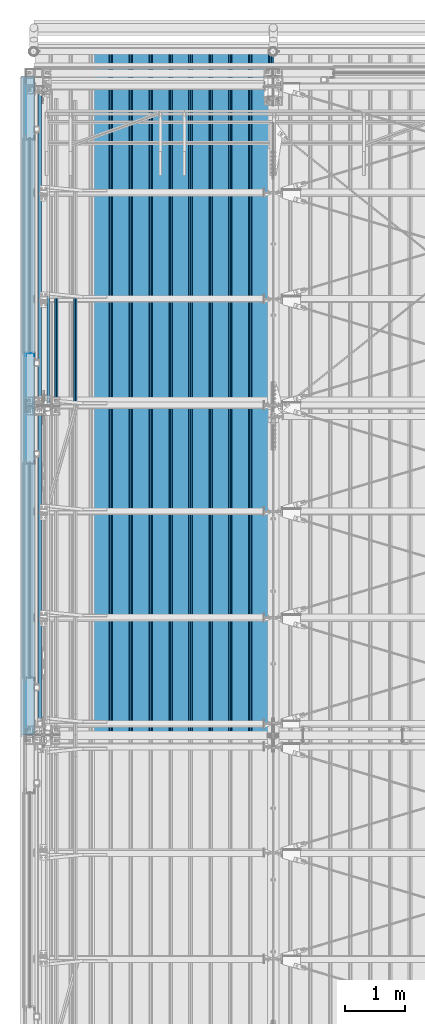
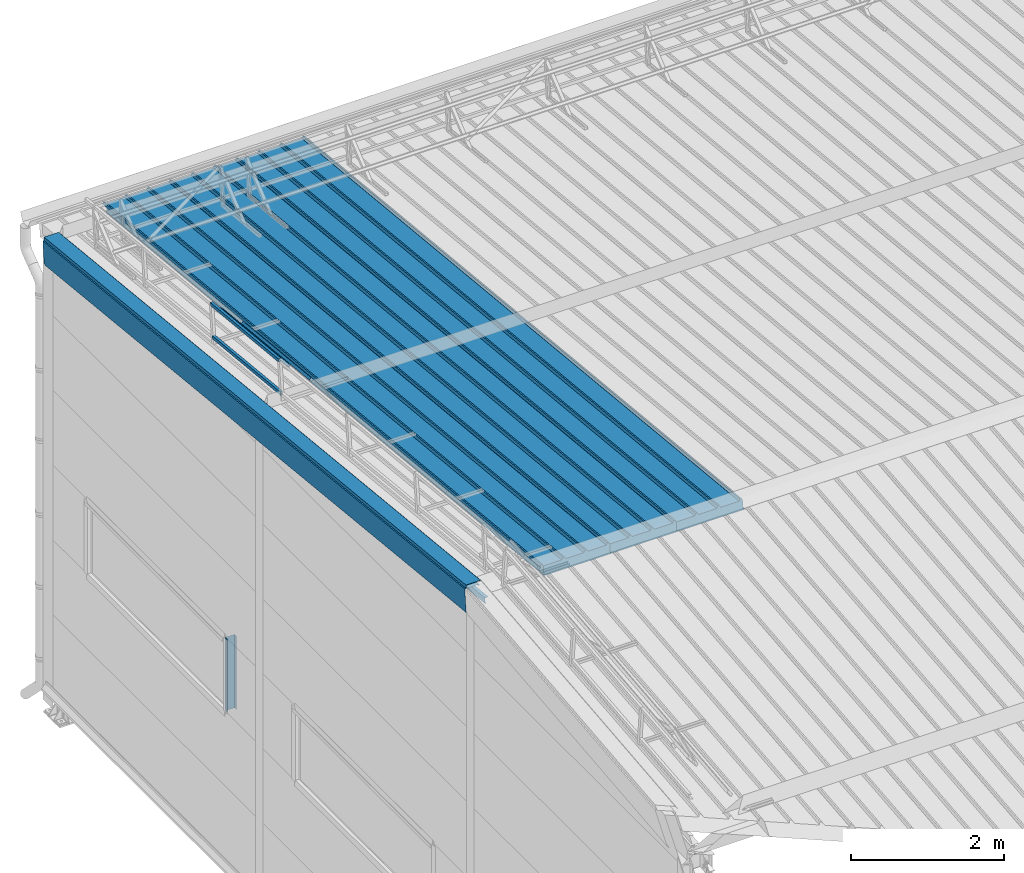
# One storey, part 48 of 709: 11 beams, 11 elements without a shape of their own.
"""IFC4 building model written with IfcOpenShell, lengths in millimetres."""

from ifc_helpers import new_model, si_unit, direction, frame, origin_with_axes, place, context, subcontext, project, spatial, line, indexed_curve, outline, extrude, material, element, aggregate, save


model = new_model("IFC4")

# Units and contexts
model_context = context("Model", 3, precision=0.2, world=origin_with_axes(), true_north=direction((0.0, 1.0)))
body_context = subcontext(model_context, "Body", "Model", "MODEL_VIEW")
ifc_project = project(units=[si_unit("LENGTHUNIT", "METRE", prefix="MILLI"), si_unit("AREAUNIT", "SQUARE_METRE"), si_unit("VOLUMEUNIT", "CUBIC_METRE"), si_unit("MASSUNIT", "GRAM", prefix="KILO"), si_unit("TIMEUNIT", "SECOND"), si_unit("PLANEANGLEUNIT", "RADIAN"), si_unit("SOLIDANGLEUNIT", "STERADIAN"), si_unit("THERMODYNAMICTEMPERATUREUNIT", "DEGREE_CELSIUS"), si_unit("LUMINOUSINTENSITYUNIT", "LUMEN")], contexts=[model_context])

# Site, building, storey
site_placement = place(None, origin_with_axes())
site = spatial("IfcSite", under=ifc_project, at=site_placement, CompositionType="ELEMENT")
building_placement = place(site_placement, origin_with_axes())
building = spatial("IfcBuilding", under=site, at=building_placement, Name="Undefined", CompositionType="ELEMENT")
storey_placement = place(building_placement, origin_with_axes())
storey = spatial("IfcBuildingStorey", under=building, at=storey_placement, Name="Undefined", CompositionType="ELEMENT", Elevation=0.0)

# Assembly, beam
assembly_1_placement = place(storey_placement, frame((3452.44, 11009.10459, 8419.96887), z_axis=(1.0, 0.0, 0.0), x_axis=(0.0, 0.9950371902, -0.099503719)))
assembly_1 = element("IfcElementAssembly", 1, at=assembly_1_placement, inside=storey)
ifc_material_1 = material(Name="Insulation", Category="Insulation")
beam_1_placement = place(assembly_1_placement, origin_with_axes())
beam_1 = element("IfcBeam", 2, at=beam_1_placement, material=ifc_material_1, ObjectType="P-99", context=body_context, shape_type="SolidModel", body=[
    extrude(outline(indexed_curve([(-509.8453, 89.5), (-490.1547, 89.5), (-471.67949, 57.5), (-471.67949, -88.5), (-436.67949, -88.5), (-436.67949, -91.5), (562.55841, -91.5), (562.55841, -89.5), (527.55841, -89.5), (527.55841, 57.5), (510.2379, 88.5), (489.7621, 88.5), (472.44159, 58.5), (196.71923, 58.5), (177.66667, 91.5), (155.66667, 91.5), (136.61411, 58.5), (-136.61411, 58.5), (-155.66667, 91.5), (-177.66667, 91.5), (-196.71923, 58.5), (-469.94744, 58.5), (-489.0, 91.5), (-511.0, 91.5), (-527.16581, 63.5), (-525.43376, 62.5)], segments=[line(1, 2, 3, 4, 5, 6, 7, 8, 9, 10, 11, 12, 13, 14, 15, 16, 17, 18, 19, 20, 21, 22, 23, 24, 25, 26, 1)])), frame((0.0, 0.0, 0.0), z_axis=(-1.0, 0.0, 0.0), x_axis=(0.0, 0.0, 1.0)), (0.0, 0.0, -1.0), 11459.0),
])
aggregate(assembly_1, [beam_1])

assembly_2_placement = place(storey_placement, frame((2452.44, 11009.10459, 8419.96887), z_axis=(1.0, 0.0, 0.0), x_axis=(0.0, 0.9950371902, -0.099503719)))
assembly_2 = element("IfcElementAssembly", 3, at=assembly_2_placement, inside=storey)
beam_2_placement = place(assembly_2_placement, origin_with_axes())
beam_2 = element("IfcBeam", 4, at=beam_2_placement, material=ifc_material_1, ObjectType="P-99", context=body_context, shape_type="SolidModel", body=[
    extrude(outline(indexed_curve([(-509.8453, 89.5), (-490.1547, 89.5), (-471.67949, 57.5), (-471.67949, -88.5), (-436.67949, -88.5), (-436.67949, -91.5), (562.55841, -91.5), (562.55841, -89.5), (527.55841, -89.5), (527.55841, 57.5), (510.2379, 88.5), (489.7621, 88.5), (472.44159, 58.5), (196.71923, 58.5), (177.66667, 91.5), (155.66667, 91.5), (136.61411, 58.5), (-136.61411, 58.5), (-155.66667, 91.5), (-177.66667, 91.5), (-196.71923, 58.5), (-469.94744, 58.5), (-489.0, 91.5), (-511.0, 91.5), (-527.16581, 63.5), (-525.43376, 62.5)], segments=[line(1, 2, 3, 4, 5, 6, 7, 8, 9, 10, 11, 12, 13, 14, 15, 16, 17, 18, 19, 20, 21, 22, 23, 24, 25, 26, 1)])), frame((0.0, 0.0, 0.0), z_axis=(-1.0, 0.0, 0.0), x_axis=(0.0, 0.0, 1.0)), (0.0, 0.0, -1.0), 11459.0),
])
aggregate(assembly_2, [beam_2])

assembly_3_placement = place(storey_placement, frame((1452.44, 11009.10459, 8419.96887), z_axis=(1.0, 0.0, 0.0), x_axis=(0.0, 0.9950371902, -0.099503719)))
assembly_3 = element("IfcElementAssembly", 5, at=assembly_3_placement, inside=storey)
beam_3_placement = place(assembly_3_placement, origin_with_axes())
beam_3 = element("IfcBeam", 6, at=beam_3_placement, material=ifc_material_1, ObjectType="P-99", context=body_context, shape_type="SolidModel", body=[
    extrude(outline(indexed_curve([(-509.8453, 89.5), (-490.1547, 89.5), (-471.67949, 57.5), (-471.67949, -88.5), (-436.67949, -88.5), (-436.67949, -91.5), (562.55841, -91.5), (562.55841, -89.5), (527.55841, -89.5), (527.55841, 57.5), (510.2379, 88.5), (489.7621, 88.5), (472.44159, 58.5), (196.71923, 58.5), (177.66667, 91.5), (155.66667, 91.5), (136.61411, 58.5), (-136.61411, 58.5), (-155.66667, 91.5), (-177.66667, 91.5), (-196.71923, 58.5), (-469.94744, 58.5), (-489.0, 91.5), (-511.0, 91.5), (-527.16581, 63.5), (-525.43376, 62.5)], segments=[line(1, 2, 3, 4, 5, 6, 7, 8, 9, 10, 11, 12, 13, 14, 15, 16, 17, 18, 19, 20, 21, 22, 23, 24, 25, 26, 1)])), frame((0.0, 0.0, 0.0), z_axis=(-1.0, 0.0, 0.0), x_axis=(0.0, 0.0, 1.0)), (0.0, 0.0, -1.0), 11459.0),
])
aggregate(assembly_3, [beam_3])

assembly_4_placement = place(storey_placement, frame((240.0, 16604.47891, 8622.71451), z_axis=(1.0, 0.0, 0.0), x_axis=(0.0, 0.9950371902, -0.099503719)))
assembly_4 = element("IfcElementAssembly", 7, at=assembly_4_placement, inside=storey)
ifc_material_2 = material(Name="Steel_Undefined", Category="STEEL")
beam_4_placement = place(assembly_4_placement, origin_with_axes())
beam_4 = element("IfcBeam", 8, at=beam_4_placement, material=ifc_material_2, ObjectType="609", context=body_context, shape_type="SolidModel", body=[
    extrude(outline(indexed_curve([(-20.0, -25.0), (20.0, -25.0), (20.0, -22.5), (-17.5, -22.5), (-17.5, 22.5), (20.0, 22.5), (20.0, 25.0), (-20.0, 25.0)], segments=[line(1, 2, 3, 4, 5, 6, 7, 8, 1)])), frame((0.0, 0.0, 0.0), z_axis=(-1.0, 0.0, 0.0), x_axis=(0.0, 0.0, 1.0)), (0.0, 0.0, -1.0), 1785.56115),
])
aggregate(assembly_4, [beam_4])

assembly_5_placement = place(storey_placement, frame((240.0, 16554.72705, 8125.19591), z_axis=(1.0, 0.0, 0.0), x_axis=(0.0, 0.9950371902, -0.099503719)))
assembly_5 = element("IfcElementAssembly", 9, at=assembly_5_placement, inside=storey)
beam_5_placement = place(assembly_5_placement, origin_with_axes())
beam_5 = element("IfcBeam", 10, at=beam_5_placement, material=ifc_material_2, ObjectType="609", context=body_context, shape_type="SolidModel", body=[
    extrude(outline(indexed_curve([(-20.0, -25.0), (20.0, -25.0), (20.0, -22.5), (-17.5, -22.5), (-17.5, 22.5), (20.0, 22.5), (20.0, 25.0), (-20.0, 25.0)], segments=[line(1, 2, 3, 4, 5, 6, 7, 8, 1)])), frame((0.0, 0.0, 0.0), z_axis=(-1.0, 0.0, 0.0), x_axis=(0.0, 0.0, 1.0)), (0.0, 0.0, -1.0), 1785.56115),
])
aggregate(assembly_5, [beam_5])

assembly_6_placement = place(storey_placement, frame((375.56349, 16591.81415, 8496.06695), z_axis=(0.707106781, 0.070359754, 0.703597545), x_axis=(0.0, 0.9950371902, -0.099503719)))
assembly_6 = element("IfcElementAssembly", 11, at=assembly_6_placement, inside=storey)
beam_6_placement = place(assembly_6_placement, origin_with_axes())
beam_6 = element("IfcBeam", 12, at=beam_6_placement, material=ifc_material_2, ObjectType="609", context=body_context, shape_type="SolidModel", body=[
    extrude(outline(indexed_curve([(-20.0, -25.0), (20.0, -25.0), (20.0, -22.5), (-17.5, -22.5), (-17.5, 22.5), (20.0, 22.5), (20.0, 25.0), (-20.0, 25.0)], segments=[line(1, 2, 3, 4, 5, 6, 7, 8, 1)])), frame((0.0, 0.0, 0.0), z_axis=(-1.0, 0.0, 0.0), x_axis=(0.0, 0.0, 1.0)), (0.0, 0.0, -1.0), 1785.56115),
])
aggregate(assembly_6, [beam_6])

assembly_7_placement = place(storey_placement, frame((692.72078, 16560.25582, 8180.48365), z_axis=(0.707106781, 0.070359754, 0.703597545), x_axis=(0.0, 0.9950371902, -0.099503719)))
assembly_7 = element("IfcElementAssembly", 13, at=assembly_7_placement, inside=storey)
beam_7_placement = place(assembly_7_placement, origin_with_axes())
beam_7 = element("IfcBeam", 14, at=beam_7_placement, material=ifc_material_2, ObjectType="609", context=body_context, shape_type="SolidModel", body=[
    extrude(outline(indexed_curve([(-20.0, -25.0), (20.0, -25.0), (20.0, -22.5), (-17.5, -22.5), (-17.5, 22.5), (20.0, 22.5), (20.0, 25.0), (-20.0, 25.0)], segments=[line(1, 2, 3, 4, 5, 6, 7, 8, 1)])), frame((0.0, 0.0, 0.0), z_axis=(-1.0, 0.0, 0.0), x_axis=(0.0, 0.0, 1.0)), (0.0, 0.0, -1.0), 1785.56115),
])
aggregate(assembly_7, [beam_7])

assembly_8_placement = place(storey_placement, frame((-60.0, 17360.0, 3870.0), z_axis=(1.0, 0.0, 0.0), x_axis=(0.0, 0.0, -1.0)))
assembly_8 = element("IfcElementAssembly", 15, at=assembly_8_placement, inside=storey)
beam_8_placement = place(assembly_8_placement, origin_with_axes())
beam_8 = element("IfcBeam", 16, at=beam_8_placement, material=ifc_material_2, context=body_context, shape_type="SolidModel", body=[
    extrude(outline(indexed_curve([(-70.0, -25.0), (-68.0, -25.0), (-68.0, 23.0), (68.0, 23.0), (68.0, -25.0), (70.0, -25.0), (70.0, 25.0), (-70.0, 25.0)], segments=[line(1, 2, 3, 4, 5, 6, 7, 8, 1)])), frame((0.0, 0.0, 0.0), z_axis=(-1.0, 0.0, 0.0), x_axis=(0.0, 0.0, 1.0)), (0.0, 0.0, -1.0), 1170.0),
])
aggregate(assembly_8, [beam_8])

assembly_9_placement = place(storey_placement, frame((-110.0, 21984.6291, 7230.46073), z_axis=(0.0, 0.102472673, 0.9947358199), x_axis=(0.0, -0.9947358198, 0.102472673)))
assembly_9 = element("IfcElementAssembly", 17, at=assembly_9_placement, inside=storey)
beam_9_placement = place(assembly_9_placement, origin_with_axes())
beam_9 = element("IfcBeam", 18, at=beam_9_placement, material=ifc_material_2, context=body_context, shape_type="SolidModel", body=[
    extrude(outline(indexed_curve([(-175.0, -100.0), (175.0, -100.0), (175.0, 100.0), (160.75, 100.0), (160.75, 124.25), (159.13, 124.25), (159.13, 104.25), (159.88, 104.25), (159.88, 123.5), (160.0, 123.5), (160.0, 99.25), (174.25, 99.25), (174.25, -99.25), (-174.25, -99.25), (-174.25, -85.0), (-198.5, -85.0), (-198.5, -84.88), (-179.25, -84.88), (-179.25, -84.13), (-199.25, -84.13), (-199.25, -85.75), (-175.0, -85.75)], segments=[line(1, 2, 3, 4, 5, 6, 7, 8, 9, 10, 11, 12, 13, 14, 15, 16, 17, 18, 19, 20, 21, 22, 1)])), frame((0.0, 0.0, 0.0), z_axis=(-1.0, 0.0, 0.0), x_axis=(0.0, 0.0, 1.0)), (0.0, 0.0, -1.0), 11058.21242),
])
aggregate(assembly_9, [beam_9])

assembly_10_placement = place(storey_placement, frame((-80.0, 22007.68545, 7454.27629), z_axis=(1.0, 0.0, 0.0), x_axis=(0.0, -0.9947358198, 0.102472673)))
assembly_10 = element("IfcElementAssembly", 19, at=assembly_10_placement, inside=storey)
beam_10_placement = place(assembly_10_placement, origin_with_axes())
beam_10 = element("IfcBeam", 20, at=beam_10_placement, material=ifc_material_2, context=body_context, shape_type="SolidModel", body=[
    extrude(outline(indexed_curve([(-110.0, -1.0), (110.0, -1.0), (131.2132, 20.2132), (129.79899, 21.62742), (109.17157, 1.0), (-108.0, 1.0), (-108.0, 49.0), (-110.0, 49.0)], segments=[line(1, 2, 3, 4, 5, 6, 7, 8, 1)])), frame((0.0, 0.0, 0.0), z_axis=(-1.0, 0.0, 0.0), x_axis=(0.0, 0.0, 1.0)), (0.0, 0.0, -1.0), 11058.21242),
])
aggregate(assembly_10, [beam_10])

assembly_11_placement = place(storey_placement, frame((80.0, 21974.38183, 7130.98715), z_axis=(0.0, 0.102472673, 0.9947358199), x_axis=(0.0, -0.9947358198, 0.102472673)))
assembly_11 = element("IfcElementAssembly", 21, at=assembly_11_placement, inside=storey)
beam_11_placement = place(assembly_11_placement, origin_with_axes())
beam_11 = element("IfcBeam", 22, at=beam_11_placement, material=ifc_material_2, context=body_context, shape_type="SolidModel", body=[
    extrude(outline(indexed_curve([(-45.0, -1.0), (45.0, -1.0), (45.0, 49.0), (43.0, 49.0), (43.0, 1.0), (-45.0, 1.0)], segments=[line(1, 2, 3, 4, 5, 6, 1)])), frame((0.0, 0.0, 0.0), z_axis=(-1.0, 0.0, 0.0), x_axis=(0.0, 0.0, 1.0)), (0.0, 0.0, -1.0), 11058.21242),
])
aggregate(assembly_11, [beam_11])

save(model, "model.ifc")
